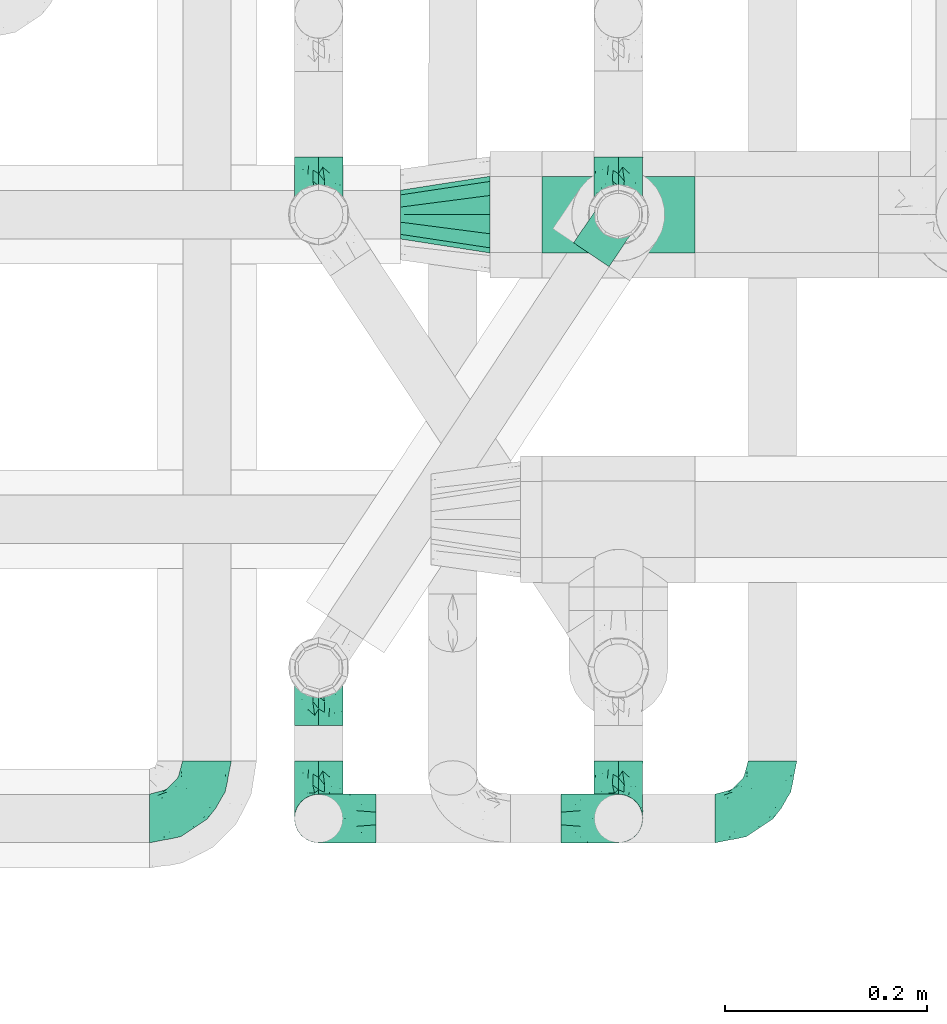
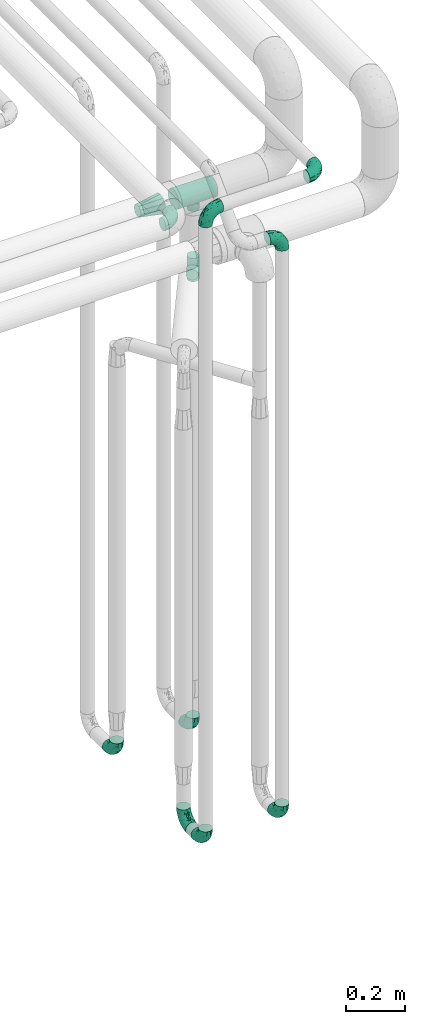
# One storey, part 665 of 827: 12 flow fittings.
"""IFC2X3 building model written with IfcOpenShell, lengths in millimetres."""

from ifc_helpers import new_model, entity, si_unit, converted_unit, derived_unit, direction, frame, origin, place, context, subcontext, project, spatial, faceted_brep, source, transform, mapped, material, type_object, type_shapes, element, save


model = new_model("IFC2X3")

# Units and contexts
model_context = context("Model", 3, precision=0.01, world=origin(), true_north=direction((6.12303176911189e-17, 1.0)))
body_context = subcontext(model_context, "Body", "Model", "MODEL_VIEW")
ifc_project = project(units=[si_unit("LENGTHUNIT", "METRE", prefix="MILLI"), si_unit("AREAUNIT", "SQUARE_METRE"), si_unit("VOLUMEUNIT", "CUBIC_METRE"), converted_unit("PLANEANGLEUNIT", "DEGREE", entity("IfcRatioMeasure", 0.0174532925199433), si_unit("PLANEANGLEUNIT", "RADIAN"), dimensions=[0, 0, 0, 0, 0, 0, 0]), si_unit("MASSUNIT", "GRAM", prefix="KILO"), derived_unit("MASSDENSITYUNIT", [(si_unit("MASSUNIT", "GRAM", prefix="KILO"), 1), (si_unit("LENGTHUNIT", "METRE"), -3)]), derived_unit("MOMENTOFINERTIAUNIT", [(si_unit("LENGTHUNIT", "METRE"), 4)]), si_unit("TIMEUNIT", "SECOND"), si_unit("FREQUENCYUNIT", "HERTZ"), si_unit("THERMODYNAMICTEMPERATUREUNIT", "DEGREE_CELSIUS"), derived_unit("THERMALTRANSMITTANCEUNIT", [(si_unit("MASSUNIT", "GRAM", prefix="KILO"), 1), (si_unit("THERMODYNAMICTEMPERATUREUNIT", "KELVIN"), -1), (si_unit("TIMEUNIT", "SECOND"), -3)]), derived_unit("VOLUMETRICFLOWRATEUNIT", [(si_unit("LENGTHUNIT", "METRE"), 3), (si_unit("TIMEUNIT", "SECOND"), -1)]), derived_unit("MASSFLOWRATEUNIT", [(si_unit("MASSUNIT", "GRAM", prefix="KILO"), 1), (si_unit("TIMEUNIT", "SECOND"), -1)]), derived_unit("ROTATIONALFREQUENCYUNIT", [(si_unit("TIMEUNIT", "SECOND"), -1)]), si_unit("ELECTRICCURRENTUNIT", "AMPERE"), si_unit("ELECTRICVOLTAGEUNIT", "VOLT"), si_unit("POWERUNIT", "WATT"), si_unit("FORCEUNIT", "NEWTON", prefix="KILO"), si_unit("ILLUMINANCEUNIT", "LUX"), si_unit("LUMINOUSFLUXUNIT", "LUMEN"), si_unit("LUMINOUSINTENSITYUNIT", "CANDELA"), derived_unit("USERDEFINED", [(si_unit("MASSUNIT", "GRAM", prefix="KILO"), -1), (si_unit("LENGTHUNIT", "METRE"), -2), (si_unit("TIMEUNIT", "SECOND"), 3), (si_unit("LUMINOUSFLUXUNIT", "LUMEN"), 1)]), derived_unit("LINEARVELOCITYUNIT", [(si_unit("LENGTHUNIT", "METRE"), 1), (si_unit("TIMEUNIT", "SECOND"), -1)]), si_unit("PRESSUREUNIT", "PASCAL"), derived_unit("USERDEFINED", [(si_unit("LENGTHUNIT", "METRE"), -2), (si_unit("MASSUNIT", "GRAM", prefix="KILO"), 1), (si_unit("TIMEUNIT", "SECOND"), -2)]), derived_unit("LINEARFORCEUNIT", [(si_unit("MASSUNIT", "GRAM", prefix="KILO"), 1), (si_unit("LENGTHUNIT", "METRE"), 1), (si_unit("TIMEUNIT", "SECOND"), -2), (si_unit("LENGTHUNIT", "METRE"), -1)]), derived_unit("PLANARFORCEUNIT", [(si_unit("MASSUNIT", "GRAM", prefix="KILO"), 1), (si_unit("LENGTHUNIT", "METRE"), 1), (si_unit("TIMEUNIT", "SECOND"), -2), (si_unit("LENGTHUNIT", "METRE"), -2)])], contexts=[model_context])

# Site, building, storey
site_placement = place(None, origin())
site = spatial("IfcSite", under=ifc_project, at=site_placement, CompositionType="ELEMENT")
building_placement = place(site_placement, origin())
building = spatial("IfcBuilding", under=site, at=building_placement, CompositionType="ELEMENT")
storey_placement = place(building_placement, frame((0.0, 0.0, 28200.0)))
storey = spatial("IfcBuildingStorey", under=building, at=storey_placement, Name="08", CompositionType="ELEMENT", Elevation=28200.0)

# Flow fittings
ifc_material = material()
pipe_fitting_type_1 = type_object("IfcPipeFittingType", Name="ADSK_1", PredefinedType="NOTDEFINED", material=ifc_material)
shared_shape_1 = source(origin(), body_context, "Body", "Brep", [
    faceted_brep([(-57.0, 12.07, -20.91), (-57.0, 6.25, -23.33), (-57.0, 0.0, -24.15), (-57.0, -6.25, -23.33), (-57.0, -12.08, -20.91), (-57.0, -17.08, -17.08), (-57.0, -20.91, -12.08), (-57.0, -23.33, -6.25), (-57.0, -24.15, 0.0), (-57.0, -23.33, 6.25), (-57.0, -20.91, 12.07), (-57.0, -17.08, 17.08), (-57.0, -12.08, 20.91), (-57.0, -6.25, 23.33), (-57.0, 0.0, 24.15), (-57.0, 6.25, 23.33), (-57.0, 12.07, 20.91), (-57.0, 17.08, 17.08), (-57.0, 20.91, 12.07), (-57.0, 23.33, 6.25), (-57.0, 24.15, 0.0), (-57.0, 23.33, -6.25), (-57.0, 20.91, -12.08), (-57.0, 17.08, -17.08), (0.0, 57.0, -24.15), (-6.25, 57.0, -23.33), (-12.07, 57.0, -20.91), (-17.08, 57.0, -17.08), (-20.91, 57.0, -12.08), (-23.33, 57.0, -6.25), (-24.15, 57.0, 0.0), (-23.33, 57.0, 6.25), (-20.91, 57.0, 12.07), (-17.08, 57.0, 17.08), (-12.07, 57.0, 20.91), (-6.25, 57.0, 23.33), (0.0, 57.0, 24.15), (6.25, 57.0, 23.33), (12.08, 57.0, 20.91), (17.08, 57.0, 17.08), (20.91, 57.0, 12.07), (23.33, 57.0, 6.25), (24.15, 57.0, 0.0), (23.33, 57.0, -6.25), (20.91, 57.0, -12.08), (17.08, 57.0, -17.08), (12.08, 57.0, -20.91), (6.25, 57.0, -23.33), (14.9, 21.14, 6.17), (13.61, 24.64, 12.48), (6.23, 8.95, 8.98), (-41.47, -21.06, 0.0), (-41.92, -18.38, 13.72), (-24.64, -13.61, 12.48), (-37.37, -13.24, 18.15), (-6.8, -4.93, 8.18), (-21.76, -15.19, 6.22), (-12.78, -9.18, 0.0), (-37.73, -20.51, 7.75), (-7.38, 7.38, 20.24), (-23.37, -4.26, 20.42), (-11.9, -3.19, 15.86), (-42.14, -8.7, 21.82), (13.24, 37.37, 18.15), (9.33, 23.53, 16.85), (4.26, 23.37, 20.42), (2.77, 10.92, 15.55), (-29.46, 0.91, 23.52), (-44.13, 20.56, 15.69), (-39.25, 26.33, 10.88), (-49.02, 22.92, 9.96), (-34.58, 23.87, 17.15), (-15.8, 6.8, 22.81), (-8.67, 20.47, 23.88), (-18.12, 12.9, 24.08), (-48.29, 14.92, 19.65), (-44.06, -2.85, 23.78), (-9.23, 48.95, 22.58), (-3.78, 42.74, 24.07), (-40.34, 4.26, 24.09), (-44.02, 26.14, 5.46), (-44.04, 9.88, 22.74), (-4.95, 16.87, 22.52), (-2.75, 1.43, 12.5), (-25.48, 40.98, 10.71), (20.51, 37.73, 7.75), (18.38, 41.92, 13.72), (8.7, 42.14, 21.82), (-25.95, -17.97, 0.0), (2.85, 44.06, 23.78), (21.06, 41.47, 0.0), (17.97, 25.95, 0.0), (-24.04, -9.27, 17.13), (-33.26, 33.26, 5.86), (-28.55, 40.57, 0.0), (-40.57, 28.55, 0.0), (-25.29, 47.19, 4.06), (-27.01, 31.1, 16.77), (-15.7, 43.95, 19.9), (-20.27, 45.22, 15.61), (-30.53, 31.98, 12.64), (-11.28, 38.33, 22.92), (-9.97, 27.88, 24.09), (-20.15, 30.26, 21.25), (-31.25, 11.75, 23.64), (-28.75, 7.23, 24.15), (-29.53, 18.06, 22.27), (-28.44, 24.21, 20.02), (-37.55, 17.7, 20.26), (-15.88, 29.25, 22.99), (-20.82, 20.82, 23.44), (-0.91, 29.46, 23.52), (-13.5, -7.67, 12.04), (1.49, 1.56, 5.16), (8.86, 10.35, 4.59), (0.38, -0.38, 0.0), (9.18, 12.78, 0.0), (-37.37, -13.24, -18.15), (8.86, 10.35, -4.59), (-45.22, 20.27, -15.61), (-43.95, 15.7, -19.9), (-38.33, 11.28, -22.92), (-48.95, 9.23, -22.58), (-47.19, 25.29, -4.06), (-33.26, 33.26, -5.86), (18.38, 41.92, -13.72), (-30.26, 20.15, -21.25), (2.85, 44.06, -23.78), (-4.26, 40.34, -24.09), (-40.98, 25.48, -10.71), (-41.92, -18.38, -13.72), (9.25, 23.5, -16.92), (4.26, 23.37, -20.42), (13.24, 37.37, -18.15), (-37.73, -20.51, -7.75), (-11.75, 31.25, -23.64), (-7.23, 28.75, -24.15), (-12.9, 18.12, -24.08), (8.7, 42.14, -21.82), (-44.06, -2.85, -23.78), (-6.8, 15.8, -22.81), (-20.47, 8.67, -23.88), (-24.64, -13.61, -12.48), (-42.74, 3.78, -24.07), (-18.06, 29.53, -22.27), (-24.21, 28.44, -20.02), (-27.88, 9.97, -24.09), (-31.1, 27.01, -16.77), (-26.14, 44.02, -5.46), (14.9, 21.14, -6.17), (20.51, 37.73, -7.75), (-9.88, 44.04, -22.74), (-20.56, 44.13, -15.69), (-21.76, -15.19, -6.22), (-13.5, -7.67, -12.04), (-24.14, -9.76, -16.74), (-11.9, -3.19, -15.86), (-14.92, 48.29, -19.65), (-23.37, -4.26, -20.42), (-0.91, 29.46, -23.52), (-26.33, 39.25, -10.88), (-23.87, 34.58, -17.15), (-42.14, -8.7, -21.82), (-22.92, 49.02, -9.96), (13.61, 24.64, -12.48), (-31.98, 30.53, -12.64), (-16.87, 4.95, -22.52), (-17.7, 37.55, -20.26), (-29.25, 15.88, -22.99), (-20.82, 20.82, -23.44), (-29.46, 0.91, -23.52), (-7.38, 7.38, -20.24), (2.77, 10.92, -15.55), (6.23, 8.95, -8.98), (-6.8, -4.93, -8.18), (-2.81, 1.41, -12.54), (1.49, 1.56, -5.16)], [[[0, 1, 2, 3, 4, 5, 6, 7, 8, 9, 10, 11, 12, 13, 14, 15, 16, 17, 18, 19, 20, 21, 22, 23]], [[24, 25, 26, 27, 28, 29, 30, 31, 32, 33, 34, 35, 36, 37, 38, 39, 40, 41, 42, 43, 44, 45, 46, 47]], [[48, 49, 50]], [[9, 8, 51]], [[52, 53, 54]], [[55, 56, 57]], [[10, 58, 52]], [[9, 58, 10]], [[59, 60, 61]], [[54, 12, 11]], [[54, 62, 12]], [[63, 39, 38]], [[64, 65, 66]], [[62, 60, 67]], [[68, 69, 70]], [[71, 69, 68]], [[72, 73, 74]], [[16, 75, 17]], [[13, 76, 14]], [[35, 77, 78]], [[14, 79, 15]], [[17, 68, 18]], [[14, 76, 79]], [[20, 19, 80]], [[70, 19, 18]], [[81, 15, 79]], [[15, 81, 16]], [[73, 72, 82]], [[66, 83, 50]], [[32, 31, 84]], [[85, 86, 49]], [[63, 87, 65]], [[56, 58, 88]], [[36, 89, 37]], [[85, 41, 40]], [[36, 35, 78]], [[90, 41, 85]], [[40, 39, 86]], [[12, 62, 13]], [[86, 85, 40]], [[48, 85, 49]], [[85, 91, 90]], [[87, 38, 37]], [[92, 60, 54]], [[80, 69, 93]], [[93, 94, 95]], [[10, 52, 11]], [[94, 96, 30]], [[97, 98, 99]], [[80, 93, 95]], [[100, 97, 84]], [[99, 98, 33]], [[101, 102, 78]], [[103, 101, 98]], [[96, 31, 30]], [[77, 98, 101]], [[77, 35, 34]], [[34, 33, 98]], [[9, 51, 58]], [[87, 63, 38]], [[104, 105, 74]], [[106, 103, 107]], [[106, 81, 104]], [[75, 68, 17]], [[108, 107, 71]], [[33, 32, 99]], [[109, 103, 110]], [[101, 109, 102]], [[89, 78, 111]], [[53, 52, 58]], [[54, 11, 52]], [[60, 62, 54]], [[88, 58, 51]], [[76, 62, 67]], [[53, 112, 92]], [[60, 59, 72]], [[39, 63, 86]], [[49, 86, 63]], [[89, 87, 37]], [[42, 41, 90]], [[111, 82, 65]], [[111, 65, 87]], [[65, 59, 66]], [[104, 81, 79]], [[75, 81, 108]], [[32, 84, 99]], [[97, 99, 84]], [[98, 97, 103]], [[106, 107, 108]], [[74, 102, 110]], [[111, 78, 102]], [[74, 110, 104]], [[74, 67, 72]], [[61, 92, 112]], [[66, 59, 61]], [[56, 53, 58]], [[66, 50, 49]], [[61, 112, 83]], [[66, 49, 64]], [[78, 89, 36]], [[87, 89, 111]], [[62, 76, 13]], [[79, 76, 67]], [[100, 93, 69]], [[96, 93, 84]], [[55, 113, 50]], [[113, 114, 50]], [[104, 79, 105]], [[106, 104, 110]], [[20, 80, 95]], [[85, 48, 91]], [[115, 114, 113]], [[116, 91, 48]], [[70, 80, 19]], [[93, 96, 94]], [[84, 31, 96]], [[103, 106, 110]], [[81, 106, 108]], [[103, 97, 107]], [[71, 107, 97]], [[71, 97, 100]], [[108, 71, 68]], [[79, 67, 105]], [[67, 74, 105]], [[115, 113, 57]], [[112, 56, 55]], [[56, 88, 57]], [[60, 72, 67]], [[82, 72, 59]], [[65, 82, 59]], [[82, 111, 73]], [[111, 102, 73]], [[102, 74, 73]], [[81, 75, 16]], [[68, 75, 108]], [[68, 70, 18]], [[80, 70, 69]], [[98, 77, 34]], [[78, 77, 101]], [[93, 100, 84]], [[71, 100, 69]], [[102, 109, 110]], [[101, 103, 109]], [[53, 92, 54]], [[61, 60, 92]], [[56, 112, 53]], [[83, 112, 55]], [[50, 83, 55]], [[61, 83, 66]], [[49, 63, 64]], [[65, 64, 63]], [[57, 113, 55]], [[114, 115, 116]], [[116, 48, 114]], [[48, 50, 114]], [[117, 5, 4]], [[116, 115, 118]], [[119, 120, 23]], [[121, 122, 120]], [[95, 123, 20]], [[0, 23, 120]], [[124, 95, 94]], [[125, 45, 44]], [[121, 120, 126]], [[24, 127, 128]], [[22, 21, 129]], [[0, 122, 1]], [[5, 117, 130]], [[131, 132, 133]], [[134, 88, 51]], [[135, 136, 137]], [[6, 5, 130]], [[46, 138, 47]], [[139, 3, 2]], [[140, 141, 137]], [[6, 134, 7]], [[134, 130, 142]], [[143, 2, 1]], [[144, 126, 145]], [[121, 146, 143]], [[147, 120, 119]], [[94, 148, 124]], [[149, 150, 91]], [[30, 29, 148]], [[151, 25, 128]], [[27, 152, 28]], [[134, 153, 88]], [[154, 155, 156]], [[27, 26, 157]], [[151, 26, 25]], [[155, 158, 156]], [[24, 47, 127]], [[1, 122, 143]], [[138, 132, 159]], [[160, 152, 161]], [[24, 128, 25]], [[46, 133, 138]], [[162, 117, 4]], [[148, 160, 124]], [[152, 160, 163]], [[154, 142, 155]], [[45, 125, 133]], [[133, 46, 45]], [[125, 164, 133]], [[51, 7, 134]], [[42, 90, 43]], [[165, 147, 129]], [[153, 134, 142]], [[43, 150, 44]], [[162, 4, 3]], [[141, 140, 166]], [[117, 162, 158]], [[163, 29, 28]], [[43, 90, 150]], [[123, 21, 20]], [[144, 151, 135]], [[157, 152, 27]], [[167, 145, 161]], [[23, 22, 119]], [[168, 126, 169]], [[121, 168, 146]], [[139, 143, 170]], [[142, 130, 117]], [[8, 7, 51]], [[134, 6, 130]], [[139, 162, 3]], [[170, 166, 158]], [[170, 158, 162]], [[158, 171, 156]], [[44, 150, 125]], [[91, 150, 90]], [[164, 125, 150]], [[132, 138, 133]], [[127, 138, 159]], [[131, 164, 172]], [[132, 171, 140]], [[135, 151, 128]], [[157, 151, 167]], [[22, 129, 119]], [[147, 119, 129]], [[120, 147, 126]], [[144, 145, 167]], [[137, 146, 169]], [[170, 143, 146]], [[137, 169, 135]], [[137, 159, 140]], [[171, 172, 156]], [[173, 174, 175]], [[156, 175, 154]], [[174, 57, 153]], [[132, 172, 171]], [[172, 164, 173]], [[143, 139, 2]], [[162, 139, 170]], [[138, 127, 47]], [[128, 127, 159]], [[165, 124, 160]], [[123, 124, 129]], [[149, 173, 164]], [[176, 174, 173]], [[135, 128, 136]], [[144, 135, 169]], [[150, 149, 164]], [[176, 118, 115]], [[149, 91, 116]], [[30, 148, 94]], [[163, 148, 29]], [[124, 123, 95]], [[129, 21, 123]], [[126, 144, 169]], [[151, 144, 167]], [[126, 147, 145]], [[161, 145, 147]], [[161, 147, 165]], [[167, 161, 152]], [[128, 159, 136]], [[159, 137, 136]], [[154, 153, 142]], [[132, 140, 159]], [[174, 176, 57]], [[57, 88, 153]], [[166, 140, 171]], [[158, 166, 171]], [[166, 170, 141]], [[170, 146, 141]], [[146, 137, 141]], [[151, 157, 26]], [[152, 157, 167]], [[152, 163, 28]], [[148, 163, 160]], [[120, 122, 0]], [[143, 122, 121]], [[124, 165, 129]], [[161, 165, 160]], [[146, 168, 169]], [[121, 126, 168]], [[142, 117, 155]], [[158, 155, 117]], [[175, 156, 172]], [[153, 154, 174]], [[173, 175, 172]], [[174, 154, 175]], [[164, 131, 133]], [[172, 132, 131]], [[176, 173, 118]], [[57, 176, 115]], [[173, 149, 118]], [[149, 116, 118]]]),
])
type_shapes(pipe_fitting_type_1, [shared_shape_1])
flow_fitting_1_placement = place(storey_placement, frame((48444.84, 13636.84, 3000.0)))
element("IfcFlowFitting", 1, at=flow_fitting_1_placement, inside=storey, type_object=pipe_fitting_type_1, material=ifc_material, Name="ADSK_1", ObjectType="ADSK_1", context=body_context, shape_type="MappedRepresentation", body=[
    mapped(shared_shape_1, transform((0.0, 0.0, 0.0), scale=1.0)),
])
for number, where, z_axis, x_axis, name in (
    (2, (47994.84, 13636.84, 3000.0), (0.0, -1.0, 0.0), (-1.0, 0.0, 0.0), "ADSK_1"),
    (3, (47994.84, 13636.84, 400.0), (1.0, 0.0, 0.0), (0.0, 0.0, -1.0), "ADSK_1"),
    (4, (48292.03, 13636.84, 400.0), (1.0, 0.0, 0.0), (0.0, 0.0, -1.0), "ADSK_1"),
    (5, (48292.03, 13636.84, 2800.0), (0.0, -1.0, 0.0), (0.0, 0.0, 1.0), "ADSK_1"),
    (6, (48292.02, 14235.68, 400.0), (-1.0, 0.0, 0.0), (0.0, -1.0, 0.0), "ADSK_1"),
    (7, (47994.84, 14235.68, 400.0), (-1.0, 0.0, 0.0), (0.0, -1.0, 0.0), "ADSK_1"),
):
    element("IfcFlowFitting", number, at=place(storey_placement, frame(where, z_axis=z_axis, x_axis=x_axis)), inside=storey, type_object=pipe_fitting_type_1, material=ifc_material, Name=name, ObjectType="ADSK_1", context=body_context, shape_type="MappedRepresentation", body=[
        mapped(shared_shape_1, transform((0.0, 0.0, 0.0), scale=1.0)),
    ])
flow_fitting_2_placement = place(storey_placement, frame((47884.01, 13636.84, 3000.0)))
element("IfcFlowFitting", 8, at=flow_fitting_2_placement, inside=storey, type_object=pipe_fitting_type_1, material=ifc_material, Name="ADSK_1", ObjectType="ADSK_1", context=body_context, shape_type="MappedRepresentation", body=[
    mapped(shared_shape_1, transform((0.0, 0.0, 0.0), scale=1.0)),
])
flow_fitting_3_placement = place(storey_placement, frame((47994.84, 13786.19, 400.0), z_axis=(1.0, 0.0, 0.0), x_axis=(0.0, 1.0, 0.0)))
element("IfcFlowFitting", 9, at=flow_fitting_3_placement, inside=storey, type_object=pipe_fitting_type_1, material=ifc_material, Name="ADSK_1", ObjectType="ADSK_1", context=body_context, shape_type="MappedRepresentation", body=[
    mapped(shared_shape_1, transform((0.0, 0.0, 0.0), scale=1.0)),
])
pipe_fitting_type_2 = type_object("IfcPipeFittingType", Name="ADSK_1", PredefinedType="NOTDEFINED", material=ifc_material)
shared_shape_2 = source(origin(), body_context, "Body", "Brep", [
    faceted_brep([(-48.0, 10.6, -18.36), (-48.0, 5.49, -20.48), (-48.0, 0.0, -21.2), (-48.0, -5.49, -20.48), (-48.0, -10.6, -18.36), (-48.0, -14.99, -14.99), (-48.0, -18.36, -10.6), (-48.0, -20.48, -5.49), (-48.0, -21.2, 0.0), (-48.0, -20.48, 5.49), (-48.0, -18.36, 10.6), (-48.0, -14.99, 14.99), (-48.0, -10.6, 18.36), (-48.0, -5.49, 20.48), (-48.0, 0.0, 21.2), (-48.0, 5.49, 20.48), (-48.0, 10.6, 18.36), (-48.0, 14.99, 14.99), (-48.0, 18.36, 10.6), (-48.0, 20.48, 5.49), (-48.0, 21.2, 0.0), (-48.0, 20.48, -5.49), (-48.0, 18.36, -10.6), (-48.0, 14.99, -14.99), (48.0, 0.0, -21.2), (48.0, 5.49, -20.48), (48.0, 10.6, -18.36), (48.0, 14.99, -14.99), (48.0, 18.36, -10.6), (48.0, 20.48, -5.49), (48.0, 21.2, 0.0), (48.0, 20.48, 5.49), (48.0, 18.36, 10.6), (48.0, 14.99, 14.99), (48.0, 10.6, 18.36), (48.0, 5.49, 20.48), (48.0, 0.0, 21.2), (48.0, -5.49, 20.48), (48.0, -10.6, 18.36), (48.0, -14.99, 14.99), (48.0, -18.36, 10.6), (48.0, -20.48, 5.49), (48.0, -21.2, 0.0), (48.0, -20.48, -5.49), (48.0, -18.36, -10.6), (48.0, -14.99, -14.99), (48.0, -10.6, -18.36), (48.0, -5.49, -20.48), (20.43, -20.43, 5.66), (21.2, -21.2, 0.0), (-21.2, -21.2, 0.0), (18.35, -18.35, 10.62), (11.88, -11.88, 17.56), (15.38, -15.38, 14.59), (-20.43, -20.43, 5.66), (-18.35, -18.35, 10.62), (-15.38, -15.38, 14.59), (-11.88, -11.88, 17.56), (-8.06, -8.06, 19.61), (8.06, -8.06, 19.61), (4.07, -4.07, 20.81), (0.0, 0.0, 21.2), (-4.07, -4.07, 20.81), (4.07, -4.07, -20.81), (0.0, 0.0, -21.2), (-4.07, -4.07, -20.81), (-8.06, -8.06, -19.61), (8.06, -8.06, -19.61), (11.88, -11.88, -17.56), (15.38, -15.38, -14.59), (18.35, -18.35, -10.62), (20.43, -20.43, -5.66), (-11.88, -11.88, -17.56), (-15.38, -15.38, -14.59), (-20.43, -20.43, -5.66), (-18.35, -18.35, -10.62), (0.0, -48.0, -21.2), (5.49, -48.0, -20.48), (10.6, -48.0, -18.36), (14.99, -48.0, -14.99), (18.36, -48.0, -10.6), (20.48, -48.0, -5.49), (21.2, -48.0, 0.0), (20.48, -48.0, 5.49), (18.36, -48.0, 10.6), (14.99, -48.0, 14.99), (10.6, -48.0, 18.36), (5.49, -48.0, 20.48), (0.0, -48.0, 21.2), (-5.49, -48.0, 20.48), (-10.6, -48.0, 18.36), (-14.99, -48.0, 14.99), (-18.36, -48.0, 10.6), (-20.48, -48.0, 5.49), (-21.2, -48.0, 0.0), (-20.48, -48.0, -5.49), (-18.36, -48.0, -10.6), (-14.99, -48.0, -14.99), (-10.6, -48.0, -18.36), (-5.49, -48.0, -20.48)], [[[0, 1, 2, 3, 4, 5, 6, 7, 8, 9, 10, 11, 12, 13, 14, 15, 16, 17, 18, 19, 20, 21, 22, 23]], [[24, 25, 26, 27, 28, 29, 30, 31, 32, 33, 34, 35, 36, 37, 38, 39, 40, 41, 42, 43, 44, 45, 46, 47]], [[41, 40, 48]], [[42, 41, 49]], [[50, 9, 8]], [[49, 41, 48]], [[40, 51, 48]], [[39, 38, 52]], [[51, 40, 53]], [[52, 53, 39]], [[53, 40, 39]], [[50, 54, 9]], [[9, 54, 10]], [[54, 55, 10]], [[56, 57, 11]], [[11, 10, 56]], [[11, 57, 12]], [[56, 10, 55]], [[12, 57, 58]], [[52, 38, 59]], [[60, 36, 61]], [[62, 61, 14]], [[59, 37, 60]], [[37, 59, 38]], [[60, 37, 36]], [[61, 36, 35, 15, 14]], [[32, 31, 19, 18]], [[17, 16, 34, 33]], [[18, 17, 33, 32]], [[35, 34, 16, 15]], [[20, 19, 31, 30]], [[62, 13, 58]], [[13, 62, 14]], [[58, 13, 12]], [[27, 23, 22, 28]], [[22, 21, 29, 28]], [[0, 23, 27, 26]], [[20, 30, 29, 21]], [[24, 47, 63]], [[24, 64, 2, 1, 25]], [[64, 24, 63]], [[2, 64, 65]], [[26, 25, 1, 0]], [[65, 66, 3]], [[2, 65, 3]], [[66, 4, 3]], [[63, 47, 67]], [[46, 45, 68]], [[69, 68, 45]], [[44, 70, 69]], [[69, 45, 44]], [[46, 68, 67]], [[43, 42, 49]], [[7, 50, 8]], [[43, 71, 44]], [[71, 43, 49]], [[44, 71, 70]], [[72, 4, 66]], [[72, 5, 4]], [[5, 72, 73]], [[5, 73, 6]], [[74, 50, 7]], [[75, 74, 6]], [[74, 7, 6]], [[75, 6, 73]], [[46, 67, 47]], [[76, 77, 78, 79, 80, 81, 82, 83, 84, 85, 86, 87, 88, 89, 90, 91, 92, 93, 94, 95, 96, 97, 98, 99]], [[50, 94, 93]], [[54, 50, 93]], [[91, 90, 57]], [[56, 92, 91]], [[54, 93, 92]], [[58, 90, 89]], [[55, 54, 92]], [[56, 55, 92]], [[58, 57, 90]], [[88, 61, 62]], [[58, 89, 62]], [[56, 91, 57]], [[62, 89, 88]], [[60, 88, 87]], [[86, 59, 87]], [[84, 83, 48]], [[53, 85, 84]], [[52, 86, 85]], [[49, 83, 82]], [[59, 60, 87]], [[52, 59, 86]], [[49, 48, 83]], [[51, 53, 84]], [[48, 51, 84]], [[52, 85, 53]], [[88, 60, 61]], [[82, 81, 49]], [[71, 49, 81]], [[69, 80, 79]], [[79, 78, 68]], [[71, 81, 80]], [[67, 78, 77]], [[70, 71, 80]], [[69, 70, 80]], [[67, 68, 78]], [[76, 64, 63]], [[67, 77, 63]], [[69, 79, 68]], [[63, 77, 76]], [[65, 76, 99]], [[98, 66, 99]], [[96, 95, 74]], [[73, 97, 96]], [[72, 98, 97]], [[50, 95, 94]], [[66, 65, 99]], [[72, 66, 98]], [[50, 74, 95]], [[75, 73, 96]], [[74, 75, 96]], [[72, 97, 73]], [[76, 65, 64]]]),
])
type_shapes(pipe_fitting_type_2, [shared_shape_2])
flow_fitting_4_placement = place(storey_placement, frame((48292.02, 14235.68, 2300.0), z_axis=(-0.829037572555032, 0.559192903470761, 0.0), x_axis=(0.0, 0.0, 1.0)))
element("IfcFlowFitting", 10, at=flow_fitting_4_placement, inside=storey, type_object=pipe_fitting_type_2, material=ifc_material, Name="ADSK_1", ObjectType="ADSK_1", context=body_context, shape_type="MappedRepresentation", body=[
    mapped(shared_shape_2, transform((0.0, 0.0, 0.0), scale=1.0)),
])
pipe_fitting_type_3 = type_object("IfcPipeFittingType", Name="ADSK_1", PredefinedType="NOTDEFINED", material=ifc_material)
shared_shape_3 = source(origin(), body_context, "Body", "Brep", [
    faceted_brep([(-76.0, 9.85, -36.75), (-76.0, 0.0, -38.05), (-76.0, -9.85, -36.75), (-76.0, -19.03, -32.95), (-76.0, -26.91, -26.91), (-76.0, -32.95, -19.03), (-76.0, -36.75, -9.85), (-76.0, -38.05, 0.0), (-76.0, -36.75, 9.85), (-76.0, -32.95, 19.02), (-76.0, -26.91, 26.91), (-76.0, -19.03, 32.95), (-76.0, -9.85, 36.75), (-76.0, 0.0, 38.05), (-76.0, 9.85, 36.75), (-76.0, 19.02, 32.95), (-76.0, 26.91, 26.91), (-76.0, 32.95, 19.02), (-76.0, 36.75, 9.85), (-76.0, 38.05, 0.0), (-76.0, 36.75, -9.85), (-76.0, 32.95, -19.03), (-76.0, 26.91, -26.91), (-76.0, 19.02, -32.95), (76.0, 26.91, -26.91), (76.0, 32.95, -19.03), (76.0, 36.75, -9.85), (76.0, 38.05, 0.0), (76.0, 36.75, 9.85), (76.0, 32.95, 19.02), (76.0, 26.91, 26.91), (76.0, 19.02, 32.95), (76.0, 9.85, 36.75), (76.0, 0.0, 38.05), (76.0, -9.85, 36.75), (76.0, -19.03, 32.95), (76.0, -26.91, 26.91), (76.0, -32.95, 19.02), (76.0, -36.75, 9.85), (76.0, -38.05, 0.0), (76.0, -36.75, -9.85), (76.0, -32.95, -19.03), (76.0, -26.91, -26.91), (76.0, -19.03, -32.95), (76.0, -9.85, -36.75), (76.0, 0.0, -38.05), (76.0, 9.85, -36.75), (76.0, 19.02, -32.95), (19.88, -37.33, 7.37), (20.54, -37.69, 3.68), (21.2, -38.05, 0.0), (16.2, -35.51, 13.68), (3.75, -31.82, 20.87), (10.67, -33.35, 18.32), (7.21, -32.58, 19.59), (-21.2, -38.05, 0.0), (-20.54, -37.69, 3.68), (-19.88, -37.33, 7.37), (-16.2, -35.51, 13.67), (-10.67, -33.35, 18.32), (-7.22, -32.59, 19.59), (-3.76, -31.82, 20.86), (0.0, -31.82, 20.86), (3.75, -31.82, -20.87), (10.67, -33.35, -18.32), (7.21, -32.58, -19.59), (16.2, -35.51, -13.68), (19.88, -37.33, -7.37), (20.54, -37.69, -3.68), (-3.76, -31.82, -20.86), (-7.22, -32.59, -19.59), (-10.67, -33.35, -18.32), (-16.2, -35.51, -13.67), (0.0, -31.82, -20.86), (-19.88, -37.33, -7.37), (-20.54, -37.69, -3.68), (0.0, -64.0, -21.2), (5.49, -64.0, -20.48), (10.6, -64.0, -18.36), (14.99, -64.0, -14.99), (18.36, -64.0, -10.6), (20.48, -64.0, -5.49), (21.2, -64.0, 0.0), (20.48, -64.0, 5.49), (18.36, -64.0, 10.6), (14.99, -64.0, 14.99), (10.6, -64.0, 18.36), (5.49, -64.0, 20.48), (0.0, -64.0, 21.2), (-5.49, -64.0, 20.48), (-10.6, -64.0, 18.36), (-14.99, -64.0, 14.99), (-18.36, -64.0, 10.6), (-20.48, -64.0, 5.49), (-21.2, -64.0, 0.0), (-20.48, -64.0, -5.49), (-18.36, -64.0, -10.6), (-14.99, -64.0, -14.99), (-10.6, -64.0, -18.36), (-5.49, -64.0, -20.48)], [[[0, 1, 2, 3, 4, 5, 6, 7, 8, 9, 10, 11, 12, 13, 14, 15, 16, 17, 18, 19, 20, 21, 22, 23]], [[24, 25, 26, 27, 28, 29, 30, 31, 32, 33, 34, 35, 36, 37, 38, 39, 40, 41, 42, 43, 44, 45, 46, 47]], [[39, 38, 48]], [[39, 48, 49, 50]], [[38, 51, 48]], [[37, 36, 52]], [[53, 51, 37]], [[37, 52, 54, 53]], [[36, 10, 52]], [[37, 51, 38]], [[7, 55, 56, 57]], [[8, 7, 57]], [[57, 58, 8]], [[9, 59, 60, 61]], [[59, 9, 58]], [[9, 61, 10]], [[58, 9, 8]], [[10, 61, 62, 52]], [[36, 35, 11, 10]], [[13, 12, 34, 33]], [[12, 11, 35, 34]], [[14, 13, 33, 32]], [[29, 28, 18, 17]], [[16, 15, 31, 30]], [[17, 16, 30, 29]], [[32, 31, 15, 14]], [[19, 18, 28, 27]], [[26, 25, 21, 20]], [[25, 24, 22, 21]], [[27, 26, 20, 19]], [[45, 44, 2, 1]], [[0, 23, 47, 46]], [[1, 0, 46, 45]], [[24, 47, 23, 22]], [[3, 2, 44, 43]], [[43, 42, 4, 3]], [[42, 41, 63]], [[41, 64, 65, 63]], [[41, 66, 64]], [[42, 63, 4]], [[40, 39, 67]], [[67, 66, 40]], [[39, 50, 68, 67]], [[40, 66, 41]], [[5, 69, 70, 71]], [[5, 4, 69]], [[71, 72, 5]], [[4, 63, 73, 69]], [[72, 74, 6]], [[74, 7, 6]], [[7, 74, 75, 55]], [[72, 6, 5]], [[76, 77, 78, 79, 80, 81, 82, 83, 84, 85, 86, 87, 88, 89, 90, 91, 92, 93, 94, 95, 96, 97, 98, 99]], [[93, 56, 94]], [[88, 61, 89]], [[60, 90, 89]], [[60, 59, 90]], [[93, 57, 56]], [[57, 93, 92]], [[49, 48, 83]], [[58, 92, 91]], [[56, 55, 94]], [[57, 92, 58]], [[86, 54, 87]], [[59, 58, 91]], [[89, 61, 60]], [[59, 91, 90]], [[88, 52, 62, 61]], [[86, 53, 54]], [[85, 53, 86]], [[48, 84, 83]], [[85, 84, 51]], [[52, 88, 87]], [[54, 52, 87]], [[53, 85, 51]], [[51, 84, 48]], [[82, 49, 83]], [[49, 82, 50]], [[81, 68, 82]], [[66, 80, 79]], [[75, 94, 55]], [[81, 67, 68]], [[80, 67, 81]], [[78, 64, 79]], [[68, 50, 82]], [[67, 80, 66]], [[77, 63, 65]], [[64, 66, 79]], [[76, 69, 73, 63]], [[98, 70, 99]], [[65, 64, 78]], [[98, 71, 70]], [[76, 63, 77]], [[75, 74, 95]], [[97, 71, 98]], [[74, 96, 95]], [[97, 96, 72]], [[69, 76, 99]], [[70, 69, 99]], [[71, 97, 72]], [[72, 96, 74]], [[94, 75, 95]], [[65, 78, 77]]]),
])
type_shapes(pipe_fitting_type_3, [shared_shape_3])
flow_fitting_5_placement = place(storey_placement, frame((48292.02, 14235.68, 2605.0), z_axis=(0.0, -1.0, 0.0), x_axis=(1.0, 0.0, 0.0)))
element("IfcFlowFitting", 11, at=flow_fitting_5_placement, inside=storey, type_object=pipe_fitting_type_3, material=ifc_material, Name="ADSK_1", ObjectType="ADSK_1", context=body_context, shape_type="MappedRepresentation", body=[
    mapped(shared_shape_3, transform((0.0, 0.0, 0.0), scale=1.0)),
])
pipe_fitting_type_4 = type_object("IfcPipeFittingType", Name="ADSK_1", PredefinedType="NOTDEFINED", material=ifc_material)
shared_shape_4 = source(origin(), body_context, "Body", "Brep", [
    faceted_brep([(89.0, 24.15, 0.0), (89.0, 21.84, 7.1), (89.0, 19.54, 14.2), (89.0, 13.5, 18.58), (89.0, 7.46, 22.97), (89.0, 0.0, 22.97), (89.0, -7.46, 22.97), (89.0, -13.5, 18.58), (89.0, -19.54, 14.2), (89.0, -21.84, 7.1), (89.0, -24.15, 0.0), (89.0, -21.84, -7.1), (89.0, -19.54, -14.2), (89.0, -13.5, -18.58), (89.0, -7.46, -22.97), (89.0, 0.0, -22.97), (89.0, 7.46, -22.97), (89.0, 13.5, -18.58), (89.0, 19.54, -14.2), (89.0, 21.84, -7.1), (0.0, 25.99, 25.99), (0.0, 32.95, 19.02), (0.0, 36.21, 6.85), (0.0, 38.05, 0.0), (0.0, 36.21, -6.85), (0.0, 32.95, -19.03), (0.0, 25.99, -25.99), (0.0, 19.03, -32.95), (0.0, 9.51, -35.5), (0.0, 0.0, -38.05), (0.0, -9.51, -35.5), (0.0, -19.03, -32.95), (0.0, -25.99, -25.99), (0.0, -32.95, -19.02), (0.0, -36.21, -6.85), (0.0, -38.05, 0.0), (0.0, -36.21, 6.85), (0.0, -32.95, 19.02), (0.0, -25.99, 25.99), (0.0, -19.02, 32.95), (0.0, -9.51, 35.5), (0.0, 0.0, 38.05), (0.0, 9.51, 35.5), (0.0, 19.02, 32.95)], [[[0, 1, 2, 3, 4, 5, 6, 7, 8, 9, 10, 11, 12, 13, 14, 15, 16, 17, 18, 19]], [[20, 21, 22, 23, 24, 25, 26, 27, 28, 29, 30, 31, 32, 33, 34, 35, 36, 37, 38, 39, 40, 41, 42, 43]], [[26, 17, 27]], [[25, 18, 26]], [[17, 26, 18]], [[25, 19, 18]], [[24, 0, 19]], [[31, 14, 13]], [[17, 16, 27]], [[28, 27, 16]], [[14, 30, 15]], [[16, 15, 28]], [[12, 32, 13]], [[10, 35, 34]], [[30, 29, 15]], [[10, 34, 11]], [[25, 24, 19]], [[14, 31, 30]], [[0, 24, 23]], [[11, 33, 12]], [[12, 33, 32]], [[33, 11, 34]], [[31, 13, 32]], [[28, 15, 29]], [[38, 7, 39]], [[37, 8, 38]], [[7, 38, 8]], [[37, 9, 8]], [[36, 10, 9]], [[43, 4, 3]], [[7, 6, 39]], [[40, 39, 6]], [[4, 42, 5]], [[6, 5, 40]], [[2, 20, 3]], [[0, 23, 22]], [[42, 41, 5]], [[0, 22, 1]], [[37, 36, 9]], [[4, 43, 42]], [[10, 36, 35]], [[1, 21, 2]], [[2, 21, 20]], [[21, 1, 22]], [[43, 3, 20]], [[40, 5, 41]]]),
])
type_shapes(pipe_fitting_type_4, [shared_shape_4])
flow_fitting_6_placement = place(storey_placement, frame((48164.84, 14235.68, 2605.0), z_axis=(0.0, 0.0, 1.0), x_axis=(-1.0, 0.0, 0.0)))
element("IfcFlowFitting", 12, at=flow_fitting_6_placement, inside=storey, type_object=pipe_fitting_type_4, material=ifc_material, Name="ADSK_1", ObjectType="ADSK_1", context=body_context, shape_type="MappedRepresentation", body=[
    mapped(shared_shape_4, transform((0.0, 0.0, 0.0), scale=1.0)),
])

save(model, "model.ifc")
